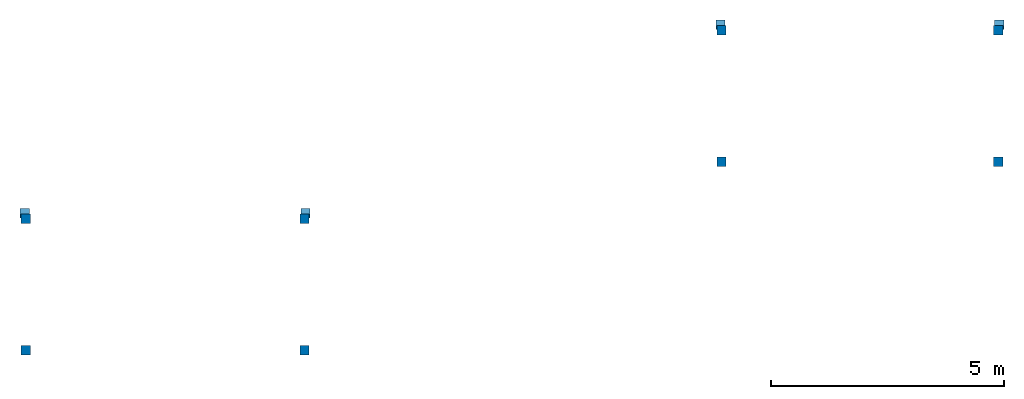
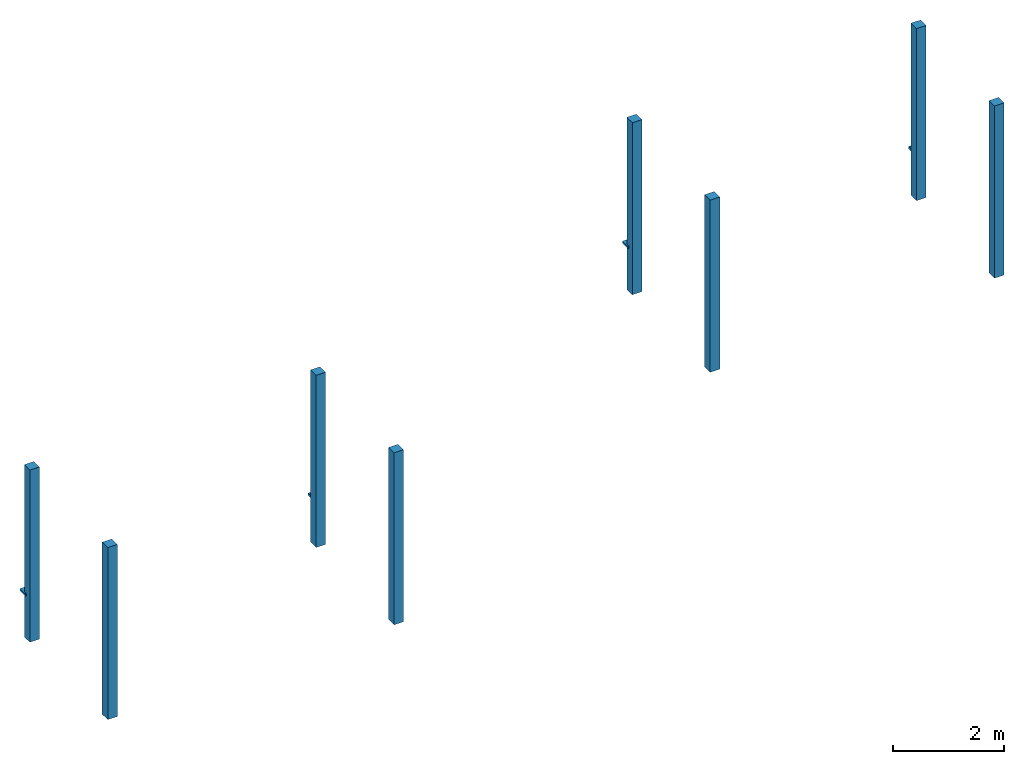
# One storey: 12 columns.
"""IFC2X3 building model written with IfcOpenShell, lengths in metres."""

from ifc_helpers import new_model, entity, si_unit, converted_unit, derived_unit, money_unit, direction, frame, origin_with_axes, origin_2d_with_axis, place, context, subcontext, project, spatial, rectangle, extrude, material, type_object, element, save


model = new_model("IFC2X3")

# Units and contexts
model_context = context("Model", 3, precision=1e-05, world=origin_with_axes(), true_north=direction((0.0, 1.0)))
body_context = subcontext(model_context, "Body", "Model", "MODEL_VIEW")
ifc_project = project(units=[si_unit("LENGTHUNIT", "METRE"), si_unit("AREAUNIT", "SQUARE_METRE"), si_unit("VOLUMEUNIT", "CUBIC_METRE"), converted_unit("PLANEANGLEUNIT", "DEGREE", entity("IfcPlaneAngleMeasure", 0.0174532925199), si_unit("PLANEANGLEUNIT", "RADIAN"), dimensions=[0, 0, 0, 0, 0, 0, 0]), si_unit("SOLIDANGLEUNIT", "STERADIAN"), money_unit("CHF"), converted_unit("TIMEUNIT", "Year", entity("IfcTimeMeasure", 31556926.0), si_unit("TIMEUNIT", "SECOND"), dimensions=[0, 0, 1, 0, 0, 0, 0]), si_unit("MASSUNIT", "GRAM", prefix="KILO"), si_unit("THERMODYNAMICTEMPERATUREUNIT", "DEGREE_CELSIUS"), si_unit("LUMINOUSINTENSITYUNIT", "LUMEN"), si_unit("ENERGYUNIT", "JOULE", prefix="MEGA"), derived_unit("THERMALCONDUCTANCEUNIT", [(si_unit("POWERUNIT", "WATT"), 1), (si_unit("LENGTHUNIT", "METRE"), -1), (si_unit("THERMODYNAMICTEMPERATUREUNIT", "KELVIN"), -1)]), derived_unit("SPECIFICHEATCAPACITYUNIT", [(si_unit("ENERGYUNIT", "JOULE"), 1), (si_unit("MASSUNIT", "GRAM", prefix="KILO"), -1), (si_unit("THERMODYNAMICTEMPERATUREUNIT", "KELVIN"), -1)]), derived_unit("MASSDENSITYUNIT", [(si_unit("MASSUNIT", "GRAM", prefix="KILO"), 1), (si_unit("VOLUMEUNIT", "CUBIC_METRE"), -1)])], contexts=[model_context])

# Site, building, storey
site_placement = place(None, origin_with_axes())
site = spatial("IfcSite", under=ifc_project, at=site_placement, CompositionType="ELEMENT")
building_placement = place(site_placement, origin_with_axes())
building = spatial("IfcBuilding", under=site, at=building_placement, CompositionType="ELEMENT")
storey_placement = place(building_placement, frame((0.0, 0.0, -0.05), z_axis=(0.0, 0.0, 1.0), x_axis=(1.0, 0.0, 0.0)))
storey = spatial("IfcBuildingStorey", under=building, at=storey_placement, Name="TN", CompositionType="ELEMENT", Elevation=-0.05)

# Columns
ifc_material = material()
column_type_1 = type_object("IfcColumnType", Name="20 X 20", PredefinedType="COLUMN")
column_1_placement = place(storey_placement, frame((86.716785775, 89.397523968, 0.0), z_axis=(0.0, 0.0, 1.0), x_axis=(-1.0, 0.0, 0.0)))
element("IfcColumn", 1, at=column_1_placement, inside=storey, type_object=column_type_1, material=ifc_material, ObjectType="COLUMN", context=body_context, shape_type="SweptSolid", body=[
    extrude(rectangle(XDim=0.2, YDim=0.2, at=origin_2d_with_axis()), origin_with_axes(), (0.0, 0.0, 1.0), 0.05),
])
column_type_2 = type_object("IfcColumnType", Name="20 X 20", PredefinedType="COLUMN")
column_2_placement = place(storey_placement, frame((71.844626364, 85.3577566782, 0.0), z_axis=(0.0, 0.0, 1.0), x_axis=(-1.0, 0.0, 0.0)))
element("IfcColumn", 2, at=column_2_placement, inside=storey, type_object=column_type_2, material=ifc_material, ObjectType="COLUMN", context=body_context, shape_type="SweptSolid", body=[
    extrude(rectangle(XDim=0.2, YDim=0.2, at=origin_2d_with_axis()), origin_with_axes(), (0.0, 0.0, 1.0), 0.05),
])
column_type_3 = type_object("IfcColumnType", Name="20 X 20", PredefinedType="COLUMN")
for number, where, z_axis, x_axis in (
    (3, (65.824626364, 85.3577566782, 0.0), (0.0, 0.0, 1.0), (0.0, -1.0, 0.0)),
    (4, (80.7410189554, 89.397523968, 0.0), (0.0, 0.0, 1.0), (0.0, -1.0, 0.0)),
):
    element("IfcColumn", number, at=place(storey_placement, frame(where, z_axis=z_axis, x_axis=x_axis)), inside=storey, type_object=column_type_3, material=ifc_material, ObjectType="COLUMN", context=body_context, shape_type="SweptSolid", body=[
        extrude(rectangle(XDim=0.2, YDim=0.2, at=origin_2d_with_axis()), origin_with_axes(), (0.0, 0.0, 1.0), 0.05),
    ])
column_type_4 = type_object("IfcColumnType", Name="20 X 20", PredefinedType="COLUMN")
column_3_placement = place(storey_placement, frame((86.696785775, 89.277523968, -0.95), z_axis=(0.0, 0.0, 1.0), x_axis=(-1.0, 0.0, 0.0)))
element("IfcColumn", 5, at=column_3_placement, inside=storey, type_object=column_type_4, material=ifc_material, ObjectType="COLUMN", context=body_context, shape_type="SweptSolid", body=[
    extrude(rectangle(XDim=0.2, YDim=0.2, at=origin_2d_with_axis()), origin_with_axes(), (0.0, 0.0, 1.0), 3.8),
])
column_type_5 = type_object("IfcColumnType", Name="20 X 20", PredefinedType="COLUMN")
for number, where, z_axis, x_axis in (
    (6, (71.824626364, 85.2377566782, -0.95), (0.0, 0.0, 1.0), (-1.0, 0.0, 0.0)),
    (7, (86.696785775, 86.457523968, -0.95), (0.0, 0.0, 1.0), (-1.0, 0.0, 0.0)),
    (8, (71.824626364, 82.4177566782, -0.95), (0.0, 0.0, 1.0), (-1.0, 0.0, 0.0)),
):
    element("IfcColumn", number, at=place(storey_placement, frame(where, z_axis=z_axis, x_axis=x_axis)), inside=storey, type_object=column_type_5, material=ifc_material, ObjectType="COLUMN", context=body_context, shape_type="SweptSolid", body=[
        extrude(rectangle(XDim=0.2, YDim=0.2, at=origin_2d_with_axis()), origin_with_axes(), (0.0, 0.0, 1.0), 3.8),
    ])
column_type_6 = type_object("IfcColumnType", Name="20 X 20", PredefinedType="COLUMN")
for number, where, z_axis, x_axis in (
    (9, (65.844626364, 85.2377566782, -0.95), (0.0, 0.0, 1.0), (0.0, -1.0, 0.0)),
    (10, (65.844626364, 82.4177566782, -0.95), (0.0, 0.0, 1.0), (0.0, -1.0, 0.0)),
    (11, (80.7610189554, 89.277523968, -0.95), (0.0, 0.0, 1.0), (0.0, -1.0, 0.0)),
    (12, (80.7610189554, 86.457523968, -0.95), (0.0, 0.0, 1.0), (0.0, -1.0, 0.0)),
):
    element("IfcColumn", number, at=place(storey_placement, frame(where, z_axis=z_axis, x_axis=x_axis)), inside=storey, type_object=column_type_6, material=ifc_material, ObjectType="COLUMN", context=body_context, shape_type="SweptSolid", body=[
        extrude(rectangle(XDim=0.2, YDim=0.2, at=origin_2d_with_axis()), origin_with_axes(), (0.0, 0.0, 1.0), 3.8),
    ])

save(model, "model.ifc")
